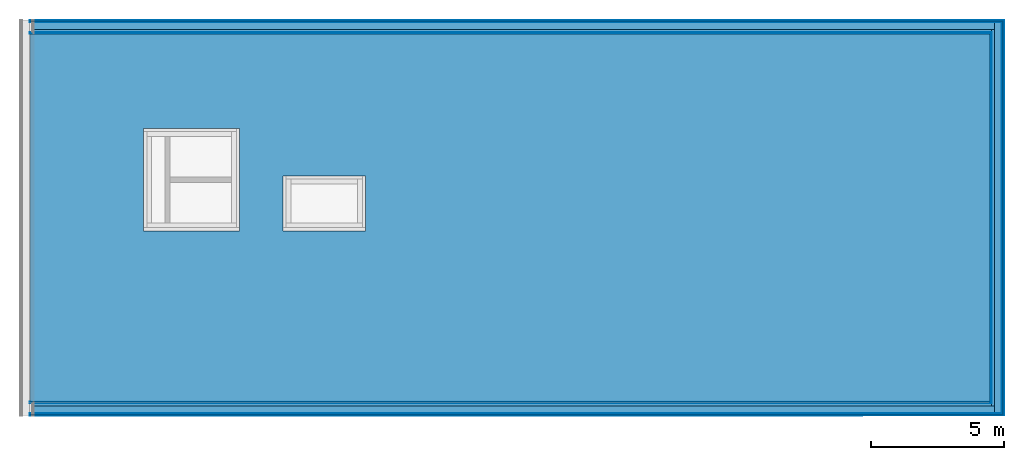
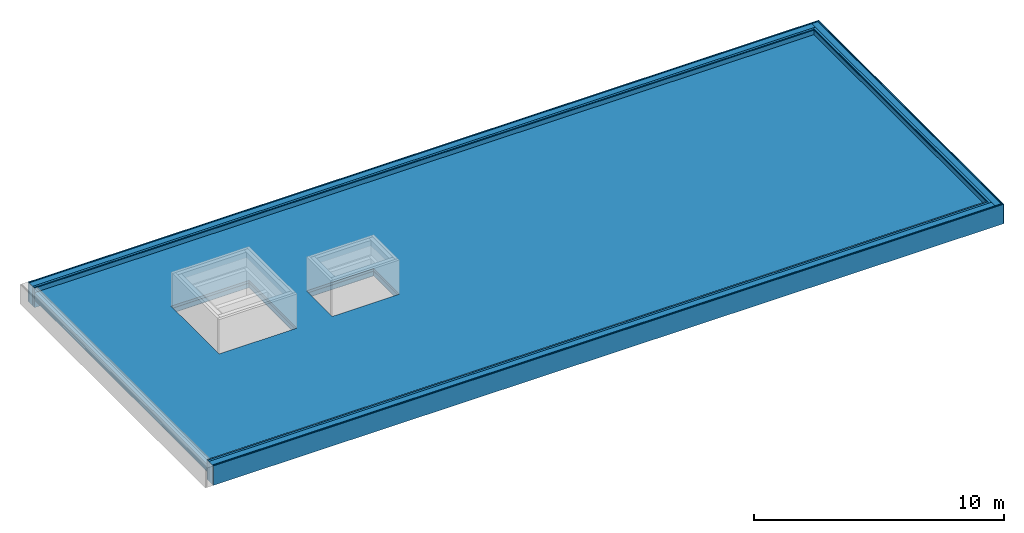
# One storey, part 2 of 3: 27 building element parts, 4 elements without a shape of their own.
"""IFC4 building model written with IfcOpenShell, lengths in metres."""

import ifcopenshell
import ifcopenshell.guid

model = None  # the IFC model being written
_history = None  # IfcOwnerHistory: only IFC2X3 demands one
_inside = {}  # id of a spatial element -> (the spatial element, [elements in it])
_under = {}  # id of a project, library or spatial element -> (it, [spatial elements below it])
_declared = {}  # id of a project -> (the project, [libraries it declares])
_typed = {}  # id of a type object -> (the type object, [elements of that type])
_made_of = {}  # id of a material, layer set ... -> (it, [elements and type objects made of it])


def new_model(schema):
    """Start an empty IFC model of exactly this schema.

    Asked for "IFC4X3", IfcOpenShell would pick the latest addendum, in which some entities
    have other attributes; the version numbers below select the first issue.
    IFC2X3 requires an IfcOwnerHistory on every rooted entity: one is made here for all.
    """
    global model, _history
    if schema == "IFC4X3":
        model = ifcopenshell.file(schema_version=(4, 3, 0, 0))
    else:
        model = ifcopenshell.file(schema=schema)
    _inside.clear()
    _under.clear()
    _declared.clear()
    _typed.clear()
    _made_of.clear()
    _history = None
    if model.schema == "IFC2X3":
        org = make("IfcOrganization", Name="unknown")
        user = make(
            "IfcPersonAndOrganization",
            ThePerson=make("IfcPerson", FamilyName="unknown"),
            TheOrganization=org,
        )
        app = make(
            "IfcApplication",
            ApplicationDeveloper=org,
            Version="unknown",
            ApplicationFullName="unknown",
            ApplicationIdentifier="unknown",
        )
        _history = make(
            "IfcOwnerHistory",
            OwningUser=user,
            OwningApplication=app,
            ChangeAction="ADDED",
            CreationDate=0,
        )
    return model


def make(cls, **values):
    """One entity of the class cls with the attributes given. An attribute that is None is left unset."""
    return model.create_entity(
        cls, **{name: value for name, value in values.items() if value is not None}
    )


def entity(cls, *values):
    """Any entity or typed value of the class cls, its attributes in the order of the schema. None: left unset."""
    e = model.create_entity(cls)
    for i, value in enumerate(values):
        if value is not None:
            e[i] = value
    return e


def rooted(cls, **values):
    """An entity with a GlobalId (a new one), such as an element, a storey or a relation."""
    return make(cls, GlobalId=ifcopenshell.guid.new(), OwnerHistory=_history, **values)


def si_unit(unit_type, name, prefix=None):
    """IfcSIUnit, for example si_unit("LENGTHUNIT", "METRE", prefix="MILLI")."""
    return make("IfcSIUnit", UnitType=unit_type, Prefix=prefix, Name=name)


def converted_unit(unit_type, name, factor, base, dimensions=None, offset=None):
    """IfcConversionBasedUnit, such as the inch: factor (a typed value) times the base unit."""
    return make(
        "IfcConversionBasedUnit"
        if offset is None
        else "IfcConversionBasedUnitWithOffset",
        ConversionOffset=offset,
        Dimensions=None
        if dimensions is None
        else entity("IfcDimensionalExponents", *dimensions),
        UnitType=unit_type,
        Name=name,
        ConversionFactor=make(
            "IfcMeasureWithUnit", ValueComponent=factor, UnitComponent=base
        ),
    )


def derived_unit(unit_type, elements):
    """IfcDerivedUnit: a product of units, each with its exponent."""
    return make(
        "IfcDerivedUnit",
        Elements=[
            make("IfcDerivedUnitElement", Unit=unit, Exponent=power)
            for unit, power in elements
        ],
        UnitType=unit_type,
    )


def assignment(units):
    """IfcUnitAssignment: the units of a project."""
    return None if units is None else make("IfcUnitAssignment", Units=units)


def point(xyz):
    """IfcCartesianPoint."""
    return None if xyz is None else make("IfcCartesianPoint", Coordinates=xyz)


def direction(xyz):
    """IfcDirection."""
    return None if xyz is None else make("IfcDirection", DirectionRatios=xyz)


def frame(location, z_axis=None, x_axis=None):
    """IfcAxis2Placement3D, a coordinate frame: its origin and axes. An axis left out is left unset."""
    return make(
        "IfcAxis2Placement3D",
        Location=point(location),
        Axis=direction(z_axis),
        RefDirection=direction(x_axis),
    )


def origin_with_axes():
    """The frame at (0, 0, 0) with the z axis (0, 0, 1) and the x axis (1, 0, 0) written out."""
    return frame((0.0, 0.0, 0.0), z_axis=(0.0, 0.0, 1.0), x_axis=(1.0, 0.0, 0.0))


def place(relative_to, where):
    """IfcLocalPlacement: puts the frame where relative to a parent placement (None: the world)."""
    return make(
        "IfcLocalPlacement", PlacementRelTo=relative_to, RelativePlacement=where
    )


def context(
    kind, dimensions, precision=None, world=None, true_north=None, identifier=None
):
    """IfcGeometricRepresentationContext, for example the 3D "Model" context."""
    return make(
        "IfcGeometricRepresentationContext",
        ContextIdentifier=identifier,
        ContextType=kind,
        CoordinateSpaceDimension=dimensions,
        Precision=precision,
        WorldCoordinateSystem=world,
        TrueNorth=true_north,
    )


def subcontext(parent, identifier, kind, view, scale=None):
    """IfcGeometricRepresentationSubContext, for example "Body" below "Model"."""
    return make(
        "IfcGeometricRepresentationSubContext",
        ContextIdentifier=identifier,
        ContextType=kind,
        ParentContext=parent,
        TargetScale=scale,
        TargetView=view,
    )


def project(units=None, contexts=None):
    """IfcProject with its units and contexts."""
    return rooted(
        "IfcProject",
        Name="project",
        RepresentationContexts=contexts,
        UnitsInContext=assignment(units),
    )


def spatial(cls, under=None, at=None, **own):
    """A site, building, storey or space (cls), placed at a placement, below another one or the project."""
    s = rooted(cls, ObjectPlacement=at, **own)
    if under is not None:
        _under.setdefault(under.id(), (under, []))[1].append(s)
    return s


def point_list(points):
    """IfcCartesianPointList2D or 3D."""
    cls = (
        "IfcCartesianPointList2D" if len(points[0]) == 2 else "IfcCartesianPointList3D"
    )
    return make(cls, CoordList=points)


def polygons(points, faces, closed=None, point_numbers=None):
    """IfcPolygonalFaceSet: a face is its outer loop, then its inner loops; points numbered from 1."""
    made = []
    for loops in faces:
        if len(loops) == 1:
            made.append(make("IfcIndexedPolygonalFace", CoordIndex=loops[0]))
        else:
            made.append(
                make(
                    "IfcIndexedPolygonalFaceWithVoids",
                    CoordIndex=loops[0],
                    InnerCoordIndices=loops[1:],
                )
            )
    return make(
        "IfcPolygonalFaceSet",
        Coordinates=point_list(points),
        Closed=closed,
        Faces=made,
        PnIndex=point_numbers,
    )


def shape(context_of_items, identifier, shape_type, items):
    """IfcShapeRepresentation: the items that make up one representation, for example the "Body"."""
    return make(
        "IfcShapeRepresentation",
        ContextOfItems=context_of_items,
        RepresentationIdentifier=identifier,
        RepresentationType=shape_type,
        Items=items,
    )


def material(Name=None, Category=None):
    """IfcMaterial."""
    return make("IfcMaterial", Name=Name, Category=Category)


def made_of(thing, what):
    """Note that an element or type object is made of a material, layer set ...; save() writes the relation."""
    if what is not None:
        _made_of.setdefault(what.id(), (what, []))[1].append(thing)
    return thing


def type_object(cls, material=None, **own):
    """A type object (cls), such as IfcWallType, which elements share."""
    return made_of(rooted(cls, **own), material)


def element(
    cls,
    number,
    at=None,
    inside=None,
    cuts=None,
    type_object=None,
    material=None,
    context=None,
    identifier="Body",
    shape_type=None,
    held_by="IfcProductDefinitionShape",
    body=None,
    shapes=None,
    **own,
):
    """One element of the class cls, such as IfcWall. Its Tag is "e" and its number.

    at: its placement. inside: the storey or other place that contains it. cuts: it is an
    opening in that element (IfcRelVoidsElement). A single representation is given by context,
    identifier, shape_type and body (its items); several are given by shapes. held_by: the class
    of the entity that holds the representations. save() writes the other relations.
    """
    e = rooted(cls, Tag="e%d" % number, ObjectPlacement=at, **own)
    if body is not None:
        shapes = [shape(context, identifier, shape_type, body)]
    if shapes is not None:
        e.Representation = make(held_by, Representations=shapes)
    if inside is not None:
        _inside.setdefault(inside.id(), (inside, []))[1].append(e)
    if cuts is not None:
        rooted(
            "IfcRelVoidsElement", RelatingBuildingElement=cuts, RelatedOpeningElement=e
        )
    if type_object is not None:
        _typed.setdefault(type_object.id(), (type_object, []))[1].append(e)
    return made_of(e, material)


def aggregate(whole, parts):
    """IfcRelAggregates: a whole, such as a stair, and the parts it consists of."""
    return rooted("IfcRelAggregates", RelatingObject=whole, RelatedObjects=parts)


def save(model, path):
    """Write the relations noted so far, then the file.

    IfcRelAggregates (storeys below a building ...), IfcRelContainedInSpatialStructure (elements
    in a storey), IfcRelDefinesByType, IfcRelAssociatesMaterial and IfcRelDeclares: one each for
    every whole, place, type object, material and project.
    """
    for whole, parts in _under.values():
        aggregate(whole, parts)
    for where, things in _inside.values():
        rooted(
            "IfcRelContainedInSpatialStructure",
            RelatedElements=things,
            RelatingStructure=where,
        )
    for kind, things in _typed.values():
        rooted("IfcRelDefinesByType", RelatedObjects=things, RelatingType=kind)
    for what, things in _made_of.values():
        rooted("IfcRelAssociatesMaterial", RelatedObjects=things, RelatingMaterial=what)
    for by, libraries in _declared.values():
        rooted("IfcRelDeclares", RelatingContext=by, RelatedDefinitions=libraries)
    model.write(path)


model = new_model("IFC4")

# Units and contexts
model_context = context("Model", 3, precision=1e-05, world=origin_with_axes(), true_north=direction((0.0, 1.0)))
body_context = subcontext(model_context, "Body", "Model", "MODEL_VIEW")
ifc_project = project(units=[si_unit("LENGTHUNIT", "METRE"), si_unit("AREAUNIT", "SQUARE_METRE"), si_unit("VOLUMEUNIT", "CUBIC_METRE"), converted_unit("PLANEANGLEUNIT", "DEGREE", entity("IfcPlaneAngleMeasure", 0.0174532925199433), si_unit("PLANEANGLEUNIT", "RADIAN"), dimensions=[0, 0, 0, 0, 0, 0, 0]), converted_unit("TIMEUNIT", "Year", entity("IfcTimeMeasure", 31557600.0), si_unit("TIMEUNIT", "SECOND"), dimensions=[0, 0, 1, 0, 0, 0, 0]), si_unit("MASSUNIT", "GRAM", prefix="KILO"), si_unit("THERMODYNAMICTEMPERATUREUNIT", "DEGREE_CELSIUS"), si_unit("LUMINOUSINTENSITYUNIT", "LUMEN"), si_unit("ENERGYUNIT", "JOULE", prefix="MEGA"), derived_unit("THERMALCONDUCTANCEUNIT", [(si_unit("POWERUNIT", "WATT"), 1), (si_unit("LENGTHUNIT", "METRE"), -1), (si_unit("THERMODYNAMICTEMPERATUREUNIT", "KELVIN"), -1)]), derived_unit("SPECIFICHEATCAPACITYUNIT", [(si_unit("ENERGYUNIT", "JOULE"), 1), (si_unit("MASSUNIT", "GRAM", prefix="KILO"), -1), (si_unit("THERMODYNAMICTEMPERATUREUNIT", "KELVIN"), -1)]), derived_unit("MASSDENSITYUNIT", [(si_unit("MASSUNIT", "GRAM", prefix="KILO"), 1), (si_unit("VOLUMEUNIT", "CUBIC_METRE"), -1)])], contexts=[model_context])

# Site, building, storey
site_placement = place(None, origin_with_axes())
site = spatial("IfcSite", under=ifc_project, at=site_placement, CompositionType="ELEMENT")
building_placement = place(site_placement, origin_with_axes())
building = spatial("IfcBuilding", under=site, at=building_placement, CompositionType="ELEMENT")
storey_placement = place(building_placement, frame((0.0, 0.0, 13.5), z_axis=(0.0, 0.0, 1.0), x_axis=(1.0, 0.0, 0.0)))
storey = spatial("IfcBuildingStorey", under=building, at=storey_placement, Name="Dach", CompositionType="ELEMENT", Elevation=13.5)

# Wall, building element parts
wall_type = type_object("IfcWallType", Name="04a-00 520", PredefinedType="NOTDEFINED")
wall_1_placement = place(storey_placement, frame((60.446, 0.0, 0.0), z_axis=(0.0, 0.0, 1.0), x_axis=(0.0, 1.0, 0.0)))
wall_1 = element("IfcWall", 1, at=wall_1_placement, inside=storey, type_object=wall_type, PredefinedType="NOTDEFINED")
ifc_material_1 = material(Name="mit")
building_element_part_1_placement = place(wall_1_placement, origin_with_axes())
building_element_part_1 = element("IfcBuildingElementPart", 2, at=building_element_part_1_placement, material=ifc_material_1, Name="mit", PredefinedType="NOTDEFINED", context=body_context, shape_type="Tessellation", body=[
    polygons([(14.33099989085795, 0.5150000000000006, 0.0), (0.515, 0.5150000000000006, 0.0), (0.515, 0.5200000000000031, 0.0), (14.3309998908572, 0.5200000000000031, 0.0), (14.33099989085795, 0.5150000000000006, 0.9500000000000028), (0.515, 0.5150000000000006, 0.9500000000000028), (0.515, 0.5200000000000031, 0.9500000000000028), (14.3309998908572, 0.5200000000000031, 0.9500000000000028)], [[[1, 2, 3, 4]], [[5, 6, 2, 1]], [[3, 2, 6, 7]], [[4, 3, 7, 8]], [[4, 8, 5, 1]], [[8, 7, 6, 5]]], closed=True),
])
ifc_material_2 = material(Name="din_18948")
building_element_part_2_placement = place(wall_1_placement, origin_with_axes())
building_element_part_2 = element("IfcBuildingElementPart", 3, at=building_element_part_2_placement, material=ifc_material_2, Name="din_18948", PredefinedType="NOTDEFINED", context=body_context, shape_type="Tessellation", body=[
    polygons([(14.35299989086125, 0.4930000000000021, 0.0), (0.493, 0.4930000000000021, 0.0), (0.4929999999999999, 0.5150000000000006, 0.0), (14.35299989085795, 0.5150000000000006, 0.0), (14.35299989086125, 0.4930000000000021, 0.9500000000000028), (0.493, 0.4930000000000021, 0.9500000000000028), (0.4929999999999999, 0.5150000000000006, 0.9500000000000028), (14.35299989085795, 0.5150000000000006, 0.9500000000000028)], [[[1, 2, 3, 4]], [[5, 6, 2, 1]], [[3, 2, 6, 7]], [[4, 3, 7, 8]], [[4, 8, 5, 1]], [[8, 7, 6, 5]]], closed=True),
])
ifc_material_3 = material(Name="holz_fichte")
building_element_part_3_placement = place(wall_1_placement, origin_with_axes())
building_element_part_3 = element("IfcBuildingElementPart", 4, at=building_element_part_3_placement, material=ifc_material_3, Name="holz_fichte", PredefinedType="NOTDEFINED", context=body_context, shape_type="Tessellation", body=[
    polygons([(14.38299989086574, 0.463000000000001, 0.0), (0.463, 0.463000000000001, 0.0), (0.4629999999999999, 0.4930000000000021, 0.0), (14.38299989086125, 0.4930000000000021, 0.0), (14.38299989086574, 0.463000000000001, 0.9500000000000028), (0.463, 0.463000000000001, 0.9500000000000028), (0.4629999999999999, 0.4930000000000021, 0.9500000000000028), (14.38299989086125, 0.4930000000000021, 0.9500000000000028)], [[[1, 2, 3, 4]], [[5, 6, 2, 1]], [[3, 2, 6, 7]], [[4, 3, 7, 8]], [[4, 8, 5, 1]], [[8, 7, 6, 5]]], closed=True),
])
ifc_material_4 = material(Name="5")
building_element_part_4_placement = place(wall_1_placement, origin_with_axes())
building_element_part_4 = element("IfcBuildingElementPart", 5, at=building_element_part_4_placement, material=ifc_material_4, Name="5", PredefinedType="NOTDEFINED", context=body_context, shape_type="Tessellation", body=[
    polygons([(14.48299989088073, 0.3629999999999995, 0.0), (0.363, 0.3629999999999995, 0.0), (0.363, 0.463000000000001, 0.0), (14.48299989086574, 0.463000000000001, 0.0), (14.48299989088073, 0.3629999999999995, 0.9500000000000028), (0.363, 0.3629999999999995, 0.9500000000000028), (0.363, 0.463000000000001, 0.9500000000000028), (14.48299989086574, 0.463000000000001, 0.9500000000000028)], [[[1, 2, 3, 4]], [[5, 6, 2, 1]], [[3, 2, 6, 7]], [[4, 3, 7, 8]], [[4, 8, 5, 1]], [[8, 7, 6, 5]]], closed=True),
])
ifc_material_5 = material()
building_element_part_5_placement = place(wall_1_placement, origin_with_axes())
building_element_part_5 = element("IfcBuildingElementPart", 6, at=building_element_part_5_placement, material=ifc_material_5, PredefinedType="NOTDEFINED", context=body_context, shape_type="Tessellation", body=[
    polygons([(14.76299989092267, 0.08299999999999841, 0.0), (0.08299999999999999, 0.08299999999999841, 0.0), (0.08299999999999999, 0.3629999999999995, 0.0), (14.76299989088072, 0.3629999999999995, 0.0), (14.76299989092267, 0.08299999999999841, 0.9500000000000028), (0.08299999999999999, 0.08299999999999841, 0.9500000000000028), (0.08299999999999999, 0.3629999999999995, 0.9500000000000028), (14.76299989088072, 0.3629999999999995, 0.9500000000000028)], [[[1, 2, 3, 4]], [[5, 6, 2, 1]], [[3, 2, 6, 7]], [[4, 3, 7, 8]], [[4, 8, 5, 1]], [[8, 7, 6, 5]]], closed=True),
])
building_element_part_6_placement = place(wall_1_placement, origin_with_axes())
building_element_part_6 = element("IfcBuildingElementPart", 7, at=building_element_part_6_placement, material=ifc_material_3, Name="holz_fichte", PredefinedType="NOTDEFINED", context=body_context, shape_type="Tessellation", body=[
    polygons([(14.82699989093226, 0.01899999999999835, 0.0), (0.019, 0.01899999999999835, 0.0), (0.019, 0.0589999999999975, 0.0), (14.82699989092627, 0.0589999999999975, 0.0), (14.82699989093226, 0.01899999999999835, 0.9500000000000028), (0.019, 0.01899999999999835, 0.9500000000000028), (0.019, 0.0589999999999975, 0.9500000000000028), (14.82699989092627, 0.0589999999999975, 0.9500000000000028)], [[[1, 2, 3, 4]], [[5, 6, 2, 1]], [[3, 2, 6, 7]], [[4, 3, 7, 8]], [[4, 8, 5, 1]], [[8, 7, 6, 5]]], closed=True),
])
ifc_material_6 = material()
building_element_part_7_placement = place(wall_1_placement, origin_with_axes())
building_element_part_7 = element("IfcBuildingElementPart", 8, at=building_element_part_7_placement, material=ifc_material_6, PredefinedType="NOTDEFINED", context=body_context, shape_type="Tessellation", body=[
    polygons([(14.84599989093511, 0.0, 0.0), (0.0, 0.0, 0.0), (0.0, 0.01899999999999835, 0.0), (14.84599989093226, 0.01899999999999835, 0.0), (14.84599989093511, 0.0, 0.9500000000000028), (0.0, 0.0, 0.9500000000000028), (0.0, 0.01899999999999835, 0.9500000000000028), (14.84599989093226, 0.01899999999999835, 0.9500000000000028)], [[[1, 2, 3, 4]], [[5, 6, 2, 1]], [[3, 2, 6, 7]], [[4, 3, 7, 8]], [[4, 8, 5, 1]], [[8, 7, 6, 5]]], closed=True),
])

wall_2_placement = place(storey_placement, frame((60.446, 14.84599989093511, 0.0), z_axis=(0.0, 0.0, 1.0), x_axis=(-1.0, -1.498251407748974e-10, 0.0)))
wall_2 = element("IfcWall", 9, at=wall_2_placement, inside=storey, type_object=wall_type, PredefinedType="NOTDEFINED")
building_element_part_8_placement = place(wall_2_placement, origin_with_axes())
building_element_part_8 = element("IfcBuildingElementPart", 10, at=building_element_part_8_placement, material=ifc_material_2, Name="din_18948", PredefinedType="NOTDEFINED", context=body_context, shape_type="Tessellation", body=[
    polygons([(36.5580000000033, 0.5149999945226895, 0.0), (36.55800000000001, 0.4929999945226911, 0.0), (0.5150000000738615, 0.4929999999228407, 0.0), (0.5150000000771584, 0.514999999922841, 0.0), (36.5580000000033, 0.5149999945226913, 0.9500000000000028), (36.55800000000001, 0.4929999945226911, 0.9500000000000028), (0.5150000000738615, 0.4929999999228407, 0.9500000000000028), (0.5150000000771584, 0.514999999922841, 0.9500000000000028)], [[[1, 2, 3, 4]], [[1, 5, 6, 2]], [[2, 6, 7, 3]], [[4, 3, 7, 8]], [[5, 1, 4, 8]], [[6, 5, 8, 7]]], closed=True),
])
building_element_part_9_placement = place(wall_2_placement, origin_with_axes())
building_element_part_9 = element("IfcBuildingElementPart", 11, at=building_element_part_9_placement, material=ifc_material_3, Name="holz_fichte", PredefinedType="NOTDEFINED", context=body_context, shape_type="Tessellation", body=[
    polygons([(36.5580000000045, 0.4929999945226911, 0.0), (36.55800000000001, 0.4629999945226899, 0.0), (0.4930000000693724, 0.4629999999261365, 0.0), (0.493000000073863, 0.4929999999261359, 0.0), (36.5580000000045, 0.4929999945226911, 0.9500000000000028), (36.55800000000001, 0.4629999945226899, 0.9500000000000028), (0.4930000000693724, 0.4629999999261365, 0.9500000000000028), (0.493000000073863, 0.4929999999261359, 0.9500000000000028)], [[[1, 2, 3, 4]], [[1, 5, 6, 2]], [[2, 6, 7, 3]], [[4, 3, 7, 8]], [[5, 1, 4, 8]], [[6, 5, 8, 7]]], closed=True),
])
building_element_part_10_placement = place(wall_2_placement, origin_with_axes())
building_element_part_10 = element("IfcBuildingElementPart", 12, at=building_element_part_10_placement, material=ifc_material_4, Name="5", PredefinedType="NOTDEFINED", context=body_context, shape_type="Tessellation", body=[
    polygons([(36.55800000001499, 0.4629999945226899, 0.0), (36.55800000000001, 0.3629999945226903, 0.0), (0.4630000000543859, 0.362999999930631, 0.0), (0.4630000000693713, 0.4629999999306325, 0.0), (36.55800000001499, 0.4629999945226899, 0.9500000000000028), (36.55800000000001, 0.3629999945226903, 0.9500000000000028), (0.4630000000543859, 0.362999999930631, 0.9500000000000028), (0.4630000000693713, 0.4629999999306325, 0.9500000000000028)], [[[1, 2, 3, 4]], [[1, 5, 6, 2]], [[2, 6, 7, 3]], [[4, 3, 7, 8]], [[5, 1, 4, 8]], [[6, 5, 8, 7]]], closed=True),
])
building_element_part_11_placement = place(wall_2_placement, origin_with_axes())
building_element_part_11 = element("IfcBuildingElementPart", 13, at=building_element_part_11_placement, material=ifc_material_1, Name="mit", PredefinedType="NOTDEFINED", context=body_context, shape_type="Tessellation", body=[
    polygons([(36.55800000000075, 0.5199999945226903, 0.0), (36.55800000000001, 0.5149999945226895, 0.0), (0.520000000077161, 0.5149999999220913, 0.0), (0.5200000000779141, 0.5199999999220903, 0.0), (36.55800000000075, 0.5199999945226903, 0.9500000000000028), (36.55800000000001, 0.5149999945226913, 0.9500000000000028), (0.520000000077161, 0.5149999999220913, 0.9500000000000028), (0.5200000000779141, 0.5199999999220903, 0.9500000000000028)], [[[1, 2, 3, 4]], [[1, 5, 6, 2]], [[2, 6, 7, 3]], [[4, 3, 7, 8]], [[5, 1, 4, 8]], [[6, 5, 8, 7]]], closed=True),
])
ifc_material_7 = material(Name="fichte")
building_element_part_12_placement = place(wall_2_placement, origin_with_axes())
building_element_part_12 = element("IfcBuildingElementPart", 14, at=building_element_part_12_placement, material=ifc_material_7, Name="fichte", PredefinedType="NOTDEFINED", context=body_context, shape_type="Tessellation", body=[
    polygons([(36.5580000000036, 0.08299999452269091, 0.0), (36.55800000000001, 0.05899999452269, 0.0), (0.08300000000883756, 0.058999999987563, 0.0), (0.0830000000124329, 0.08299999998756391, 0.0), (36.5580000000036, 0.08299999452269091, 0.9500000000000028), (36.55800000000001, 0.05899999452269, 0.9500000000000028), (0.08300000000883756, 0.058999999987563, 0.9500000000000028), (0.0830000000124329, 0.08299999998756391, 0.9500000000000028)], [[[1, 2, 3, 4]], [[1, 5, 6, 2]], [[2, 6, 7, 3]], [[4, 3, 7, 8]], [[5, 1, 4, 8]], [[6, 5, 8, 7]]], closed=True),
])
building_element_part_13_placement = place(wall_2_placement, origin_with_axes())
building_element_part_13 = element("IfcBuildingElementPart", 15, at=building_element_part_13_placement, material=ifc_material_3, Name="holz_fichte", PredefinedType="NOTDEFINED", context=body_context, shape_type="Tessellation", body=[
    polygons([(36.558000000006, 0.05899999452269, 0.0), (36.55800000000001, 0.01899999452269086, 0.0), (0.05900000000284678, 0.01899999999116098, 0.0), (0.05900000000883665, 0.05899999999116012, 0.0), (36.558000000006, 0.05899999452269, 0.9500000000000028), (36.55800000000001, 0.01899999452269086, 0.9500000000000028), (0.05900000000284678, 0.01899999999116098, 0.9500000000000028), (0.05900000000883665, 0.05899999999116012, 0.9500000000000028)], [[[1, 2, 3, 4]], [[1, 5, 6, 2]], [[2, 6, 7, 3]], [[4, 3, 7, 8]], [[5, 1, 4, 8]], [[6, 5, 8, 7]]], closed=True),
])
building_element_part_14_placement = place(wall_2_placement, origin_with_axes())
building_element_part_14 = element("IfcBuildingElementPart", 16, at=building_element_part_14_placement, material=ifc_material_5, PredefinedType="NOTDEFINED", context=body_context, shape_type="Tessellation", body=[
    polygons([(36.55800000004196, 0.3629999945226903, 0.0), (36.55800000000001, 0.08299999452269091, 0.0), (0.363000000012434, 0.08299999994561347, 0.0), (0.3630000000543845, 0.3629999999456128, 0.0), (36.55800000004196, 0.3629999945226903, 0.9500000000000028), (36.55800000000001, 0.08299999452269091, 0.9500000000000028), (0.363000000012434, 0.08299999994561347, 0.9500000000000028), (0.3630000000543845, 0.3629999999456128, 0.9500000000000028)], [[[1, 2, 3, 4]], [[1, 5, 6, 2]], [[2, 6, 7, 3]], [[4, 3, 7, 8]], [[5, 1, 4, 8]], [[6, 5, 8, 7]]], closed=True),
])
building_element_part_15_placement = place(wall_2_placement, origin_with_axes())
building_element_part_15 = element("IfcBuildingElementPart", 17, at=building_element_part_15_placement, material=ifc_material_6, PredefinedType="NOTDEFINED", context=body_context, shape_type="Tessellation", body=[
    polygons([(36.55800000000285, 0.01899999452269086, 0.0), (36.55800000000001, -5.477309272805542e-09, 0.0), (0.01899999999999835, 0.0, 0.0), (0.01900000000284763, 0.01899999999715263, 0.0), (36.55800000000285, 0.01899999452269086, 0.9500000000000028), (36.55800000000001, -5.477309272805542e-09, 0.9500000000000028), (0.01899999999999835, 0.0, 0.9500000000000028), (0.01900000000284763, 0.01899999999715263, 0.9500000000000028)], [[[1, 2, 3, 4]], [[1, 5, 6, 2]], [[2, 6, 7, 3]], [[4, 3, 7, 8]], [[5, 1, 4, 8]], [[6, 5, 8, 7]]], closed=True),
])
aggregate(wall_2, [building_element_part_8, building_element_part_9, building_element_part_10, building_element_part_11, building_element_part_12, building_element_part_13, building_element_part_14, building_element_part_15])

# Building element part
building_element_part_16_placement = place(wall_1_placement, origin_with_axes())
building_element_part_16 = element("IfcBuildingElementPart", 18, at=building_element_part_16_placement, material=ifc_material_7, Name="fichte", PredefinedType="NOTDEFINED", context=body_context, shape_type="Tessellation", body=[
    polygons([(14.78699989092627, 0.0589999999999975, 0.0), (0.059, 0.0589999999999975, 0.0), (0.05899999999999999, 0.08299999999999841, 0.0), (14.78699989092268, 0.08299999999999841, 0.0), (14.78699989092627, 0.0589999999999975, 0.9500000000000028), (0.059, 0.0589999999999975, 0.9500000000000028), (0.05899999999999999, 0.08299999999999841, 0.9500000000000028), (14.78699989092268, 0.08299999999999841, 0.9500000000000028)], [[[1, 2, 3, 4]], [[5, 6, 2, 1]], [[3, 2, 6, 7]], [[4, 3, 7, 8]], [[4, 8, 5, 1]], [[8, 7, 6, 5]]], closed=True),
])

aggregate(wall_1, [building_element_part_1, building_element_part_2, building_element_part_3, building_element_part_4, building_element_part_5, building_element_part_6, building_element_part_7, building_element_part_16])

# Covering, building element parts
covering_type = type_object("IfcCoveringType", Name="Kies 360", PredefinedType="ROOFING")
covering_placement = place(storey_placement, frame((23.88799999999999, 0.52, 0.7300000000000004), z_axis=(0.0, 0.0, 1.0), x_axis=(1.0, 0.0, 0.0)))
covering = element("IfcCovering", 19, at=covering_placement, inside=storey, type_object=covering_type, Name="Decke-001", PredefinedType="ROOFING")
ifc_material_8 = material(Name="Kies")
building_element_part_17_placement = place(covering_placement, origin_with_axes())
building_element_part_17 = element("IfcBuildingElementPart", 20, at=building_element_part_17_placement, material=ifc_material_8, Name="Kies", PredefinedType="NOTDEFINED", context=body_context, shape_type="Tessellation", body=[
    polygons([(36.038, 0.0, -0.1199999999999992), (36.038, 0.0, 0.0), (0.0, 0.0, 0.0), (0.0, 0.0, -0.1199999999999992), (36.038, 13.8059998825556, -0.1199999999999992), (36.038, 13.8059998825556, 0.0), (0.0, 13.8059998825556, 0.0), (4.270000000000014, 10.25499994546756, 0.0), (7.870000000000015, 10.25499994546756, 0.0), (7.870000000000015, 6.414999945467553, 0.0), (4.270000000000014, 6.414999945467553, 0.0), (9.497000000000007, 8.47299994546756, 0.0), (12.605, 8.47299994546756, 0.0), (12.605, 6.414999945467555, 0.0), (9.497000000000007, 6.414999945467555, 0.0), (0.0, 13.8059998825556, -0.1199999999999992), (4.270000000000014, 10.25499994546756, -0.1199999999999992), (4.270000000000014, 6.414999945467553, -0.1199999999999992), (7.870000000000015, 6.414999945467553, -0.1199999999999992), (7.870000000000015, 10.25499994546756, -0.1199999999999992), (9.497000000000007, 8.47299994546756, -0.1199999999999992), (9.497000000000007, 6.414999945467555, -0.1199999999999992), (12.605, 6.414999945467555, -0.1199999999999992), (12.605, 8.47299994546756, -0.1199999999999992)], [[[1, 2, 3, 4]], [[5, 6, 2, 1]], [[3, 2, 6, 7], [8, 9, 10, 11], [12, 13, 14, 15]], [[4, 3, 7, 16]], [[4, 16, 5, 1], [17, 18, 19, 20], [21, 22, 23, 24]], [[16, 7, 6, 5]], [[20, 9, 8, 17]], [[19, 10, 9, 20]], [[18, 11, 10, 19]], [[17, 8, 11, 18]], [[24, 13, 12, 21]], [[23, 14, 13, 24]], [[22, 15, 14, 23]], [[21, 12, 15, 22]]], closed=True),
])
ifc_material_9 = material(Name="XPS")
building_element_part_18_placement = place(covering_placement, origin_with_axes())
building_element_part_18 = element("IfcBuildingElementPart", 21, at=building_element_part_18_placement, material=ifc_material_9, Name="XPS", PredefinedType="NOTDEFINED", context=body_context, shape_type="Tessellation", body=[
    polygons([(36.038, 0.0, -0.3450000000000006), (36.038, 0.0, -0.125), (0.0, 0.0, -0.125), (0.0, 0.0, -0.3450000000000006), (36.038, 13.8059998825556, -0.3450000000000006), (36.038, 13.8059998825556, -0.125), (0.0, 13.8059998825556, -0.125), (4.270000000000014, 10.25499994546756, -0.125), (7.870000000000015, 10.25499994546756, -0.125), (7.870000000000015, 6.414999945467553, -0.125), (4.270000000000014, 6.414999945467553, -0.125), (9.497000000000007, 8.47299994546756, -0.125), (12.605, 8.47299994546756, -0.125), (12.605, 6.414999945467555, -0.125), (9.497000000000007, 6.414999945467555, -0.125), (0.0, 13.8059998825556, -0.3450000000000006), (4.270000000000014, 10.25499994546756, -0.3450000000000006), (4.270000000000014, 6.414999945467553, -0.3450000000000006), (7.870000000000015, 6.414999945467553, -0.3450000000000006), (7.870000000000015, 10.25499994546756, -0.3450000000000006), (9.497000000000007, 8.47299994546756, -0.3450000000000006), (9.497000000000007, 6.414999945467555, -0.3450000000000006), (12.605, 6.414999945467555, -0.3450000000000006), (12.605, 8.47299994546756, -0.3450000000000006)], [[[1, 2, 3, 4]], [[5, 6, 2, 1]], [[3, 2, 6, 7], [8, 9, 10, 11], [12, 13, 14, 15]], [[4, 3, 7, 16]], [[4, 16, 5, 1], [17, 18, 19, 20], [21, 22, 23, 24]], [[16, 7, 6, 5]], [[20, 9, 8, 17]], [[19, 10, 9, 20]], [[18, 11, 10, 19]], [[17, 8, 11, 18]], [[24, 13, 12, 21]], [[23, 14, 13, 24]], [[22, 15, 14, 23]], [[21, 12, 15, 22]]], closed=True),
])
ifc_material_10 = material(Name="Folie")
building_element_part_19_placement = place(covering_placement, origin_with_axes())
building_element_part_19 = element("IfcBuildingElementPart", 22, at=building_element_part_19_placement, material=ifc_material_10, Name="Folie", PredefinedType="NOTDEFINED", context=body_context, shape_type="Tessellation", body=[
    polygons([(36.038, 0.0, -0.125), (36.038, 0.0, -0.1199999999999992), (0.0, 0.0, -0.1199999999999992), (0.0, 0.0, -0.125), (36.038, 13.8059998825556, -0.125), (36.038, 13.8059998825556, -0.1199999999999992), (0.0, 13.8059998825556, -0.1199999999999992), (4.270000000000014, 10.25499994546756, -0.1199999999999992), (7.870000000000015, 10.25499994546756, -0.1199999999999992), (7.870000000000015, 6.414999945467553, -0.1199999999999992), (4.270000000000014, 6.414999945467553, -0.1199999999999992), (9.497000000000007, 8.47299994546756, -0.1199999999999992), (12.605, 8.47299994546756, -0.1199999999999992), (12.605, 6.414999945467555, -0.1199999999999992), (9.497000000000007, 6.414999945467555, -0.1199999999999992), (0.0, 13.8059998825556, -0.125), (4.270000000000014, 10.25499994546756, -0.125), (4.270000000000014, 6.414999945467553, -0.125), (7.870000000000015, 6.414999945467553, -0.125), (7.870000000000015, 10.25499994546756, -0.125), (9.497000000000007, 8.47299994546756, -0.125), (9.497000000000007, 6.414999945467555, -0.125), (12.605, 6.414999945467555, -0.125), (12.605, 8.47299994546756, -0.125)], [[[1, 2, 3, 4]], [[5, 6, 2, 1]], [[3, 2, 6, 7], [8, 9, 10, 11], [12, 13, 14, 15]], [[4, 3, 7, 16]], [[4, 16, 5, 1], [17, 18, 19, 20], [21, 22, 23, 24]], [[16, 7, 6, 5]], [[20, 9, 8, 17]], [[19, 10, 9, 20]], [[18, 11, 10, 19]], [[17, 8, 11, 18]], [[24, 13, 12, 21]], [[23, 14, 13, 24]], [[22, 15, 14, 23]], [[21, 12, 15, 22]]], closed=True),
])
building_element_part_20_placement = place(covering_placement, origin_with_axes())
building_element_part_20 = element("IfcBuildingElementPart", 23, at=building_element_part_20_placement, material=ifc_material_10, Name="Folie", PredefinedType="NOTDEFINED", context=body_context, shape_type="Tessellation", body=[
    polygons([(0.0, 0.0, -0.3599999999999994), (36.038, 0.0, -0.3599999999999994), (36.038, 0.0, -0.3450000000000006), (0.0, 0.0, -0.3450000000000006), (0.0, 13.8059998825556, -0.3599999999999994), (36.038, 13.8059998825556, -0.3599999999999994), (4.270000000000014, 10.25499994546756, -0.3599999999999994), (4.270000000000014, 6.414999945467553, -0.3599999999999994), (7.870000000000015, 6.414999945467553, -0.3599999999999994), (7.870000000000015, 10.25499994546756, -0.3599999999999994), (9.497000000000007, 8.47299994546756, -0.3599999999999994), (9.497000000000007, 6.414999945467555, -0.3599999999999994), (12.605, 6.414999945467555, -0.3599999999999994), (12.605, 8.47299994546756, -0.3599999999999994), (36.038, 13.8059998825556, -0.3450000000000006), (0.0, 13.8059998825556, -0.3450000000000006), (4.270000000000014, 10.25499994546756, -0.3450000000000006), (7.870000000000015, 10.25499994546756, -0.3450000000000006), (7.870000000000015, 6.414999945467553, -0.3450000000000006), (4.270000000000014, 6.414999945467553, -0.3450000000000006), (9.497000000000007, 8.47299994546756, -0.3450000000000006), (12.605, 8.47299994546756, -0.3450000000000006), (12.605, 6.414999945467555, -0.3450000000000006), (9.497000000000007, 6.414999945467555, -0.3450000000000006)], [[[1, 2, 3, 4]], [[1, 5, 6, 2], [7, 8, 9, 10], [11, 12, 13, 14]], [[2, 6, 15, 3]], [[4, 3, 15, 16], [17, 18, 19, 20], [21, 22, 23, 24]], [[5, 1, 4, 16]], [[6, 5, 16, 15]], [[8, 7, 17, 20]], [[9, 8, 20, 19]], [[10, 9, 19, 18]], [[7, 10, 18, 17]], [[12, 11, 21, 24]], [[13, 12, 24, 23]], [[14, 13, 23, 22]], [[11, 14, 22, 21]]], closed=True),
])
aggregate(covering, [building_element_part_17, building_element_part_18, building_element_part_19, building_element_part_20])

# Wall, building element parts
wall_3_placement = place(storey_placement, frame((23.88799999999999, 0.0, 0.0), z_axis=(0.0, 0.0, 1.0), x_axis=(1.0, 0.0, 0.0)))
wall_3 = element("IfcWall", 24, at=wall_3_placement, inside=storey, type_object=wall_type, PredefinedType="NOTDEFINED")
building_element_part_21_placement = place(wall_3_placement, origin_with_axes())
building_element_part_21 = element("IfcBuildingElementPart", 25, at=building_element_part_21_placement, material=ifc_material_3, Name="holz_fichte", PredefinedType="NOTDEFINED", context=body_context, shape_type="Tessellation", body=[
    polygons([(36.065, 0.4630000000000022, 0.0), (0.0, 0.4630000000000001, 0.0), (0.0, 0.4930000000000001, 0.0), (36.065, 0.4930000000000023, 0.0), (36.065, 0.4630000000000023, 0.9500000000000028), (0.0, 0.4630000000000001, 0.9500000000000028), (0.0, 0.4930000000000002, 0.9500000000000028), (36.065, 0.4930000000000023, 0.9500000000000028)], [[[1, 2, 3, 4]], [[5, 6, 2, 1]], [[3, 2, 6, 7]], [[4, 3, 7, 8]], [[4, 8, 5, 1]], [[8, 7, 6, 5]]], closed=True),
])
building_element_part_22_placement = place(wall_3_placement, origin_with_axes())
building_element_part_22 = element("IfcBuildingElementPart", 26, at=building_element_part_22_placement, material=ifc_material_4, Name="5", PredefinedType="NOTDEFINED", context=body_context, shape_type="Tessellation", body=[
    polygons([(36.09500000000001, 0.3630000000000023, 0.0), (0.0, 0.3630000000000001, 0.0), (0.0, 0.4630000000000001, 0.0), (36.09500000000001, 0.4630000000000022, 0.0), (36.09500000000001, 0.3630000000000023, 0.9500000000000028), (0.0, 0.3630000000000002, 0.9500000000000028), (0.0, 0.4630000000000001, 0.9500000000000028), (36.09500000000001, 0.4630000000000023, 0.9500000000000028)], [[[1, 2, 3, 4]], [[5, 6, 2, 1]], [[3, 2, 6, 7]], [[4, 3, 7, 8]], [[4, 8, 5, 1]], [[8, 7, 6, 5]]], closed=True),
])
building_element_part_23_placement = place(wall_3_placement, origin_with_axes())
building_element_part_23 = element("IfcBuildingElementPart", 27, at=building_element_part_23_placement, material=ifc_material_1, Name="mit", PredefinedType="NOTDEFINED", context=body_context, shape_type="Tessellation", body=[
    polygons([(36.038, 0.5150000000000023, 0.0), (0.0, 0.5150000000000001, 0.0), (0.0, 0.5200000000000001, 0.0), (36.038, 0.5200000000000023, 0.0), (36.038, 0.5150000000000025, 0.9500000000000028), (0.0, 0.5150000000000002, 0.9500000000000028), (0.0, 0.5200000000000002, 0.9500000000000028), (36.038, 0.5200000000000025, 0.9500000000000028)], [[[1, 2, 3, 4]], [[5, 6, 2, 1]], [[3, 2, 6, 7]], [[4, 3, 7, 8]], [[4, 8, 5, 1]], [[8, 7, 6, 5]]], closed=True),
])
building_element_part_24_placement = place(wall_3_placement, origin_with_axes())
building_element_part_24 = element("IfcBuildingElementPart", 28, at=building_element_part_24_placement, material=ifc_material_5, PredefinedType="NOTDEFINED", context=body_context, shape_type="Tessellation", body=[
    polygons([(36.19500000000001, 0.08300000000000222, 0.0), (0.0, 0.083, 0.0), (0.0, 0.363, 0.0), (36.19500000000001, 0.3630000000000023, 0.0), (36.19500000000001, 0.08300000000000228, 0.9500000000000028), (0.0, 0.08300000000000006, 0.9500000000000028), (0.0, 0.3630000000000001, 0.9500000000000028), (36.19500000000001, 0.3630000000000023, 0.9500000000000028)], [[[1, 2, 3, 4]], [[5, 6, 2, 1]], [[3, 2, 6, 7]], [[4, 3, 7, 8]], [[4, 8, 5, 1]], [[8, 7, 6, 5]]], closed=True),
])
building_element_part_25_placement = place(wall_3_placement, origin_with_axes())
building_element_part_25 = element("IfcBuildingElementPart", 29, at=building_element_part_25_placement, material=ifc_material_7, Name="fichte", PredefinedType="NOTDEFINED", context=body_context, shape_type="Tessellation", body=[
    polygons([(36.47500000000001, 0.05900000000000222, 0.0), (0.0, 0.059, 0.0), (0.0, 0.083, 0.0), (36.47500000000001, 0.08300000000000225, 0.0), (36.47500000000001, 0.05900000000000228, 0.9500000000000028), (0.0, 0.05900000000000005, 0.9500000000000028), (0.0, 0.08300000000000006, 0.9500000000000028), (36.47500000000001, 0.08300000000000231, 0.9500000000000028)], [[[1, 2, 3, 4]], [[5, 6, 2, 1]], [[3, 2, 6, 7]], [[4, 3, 7, 8]], [[4, 8, 5, 1]], [[8, 7, 6, 5]]], closed=True),
])
building_element_part_26_placement = place(wall_3_placement, origin_with_axes())
building_element_part_26 = element("IfcBuildingElementPart", 30, at=building_element_part_26_placement, material=ifc_material_6, PredefinedType="NOTDEFINED", context=body_context, shape_type="Tessellation", body=[
    polygons([(36.53900000000001, 0.0, 0.0), (0.0, 0.0, 0.0), (0.0, 0.019, 0.0), (36.53900000000001, 0.01900000000000224, 0.0), (36.53900000000001, 0.0, 0.9500000000000028), (0.0, 0.0, 0.9500000000000028), (0.0, 0.01900000000000006, 0.9500000000000028), (36.53900000000001, 0.0190000000000023, 0.9500000000000028)], [[[1, 2, 3, 4]], [[5, 6, 2, 1]], [[3, 2, 6, 7]], [[4, 3, 7, 8]], [[4, 8, 5, 1]], [[8, 7, 6, 5]]], closed=True),
])
building_element_part_27_placement = place(wall_3_placement, origin_with_axes())
building_element_part_27 = element("IfcBuildingElementPart", 31, at=building_element_part_27_placement, material=ifc_material_3, Name="holz_fichte", PredefinedType="NOTDEFINED", context=body_context, shape_type="Tessellation", body=[
    polygons([(36.49900000000001, 0.01900000000000223, 0.0), (0.0, 0.019, 0.0), (0.0, 0.059, 0.0), (36.49900000000001, 0.05900000000000222, 0.0), (36.49900000000001, 0.01900000000000229, 0.9500000000000028), (0.0, 0.01900000000000006, 0.9500000000000028), (0.0, 0.05900000000000005, 0.9500000000000028), (36.49900000000001, 0.05900000000000228, 0.9500000000000028)], [[[1, 2, 3, 4]], [[5, 6, 2, 1]], [[3, 2, 6, 7]], [[4, 3, 7, 8]], [[4, 8, 5, 1]], [[8, 7, 6, 5]]], closed=True),
])
aggregate(wall_3, [building_element_part_21, building_element_part_22, building_element_part_23, building_element_part_24, building_element_part_25, building_element_part_26, building_element_part_27])

save(model, "model.ifc")
